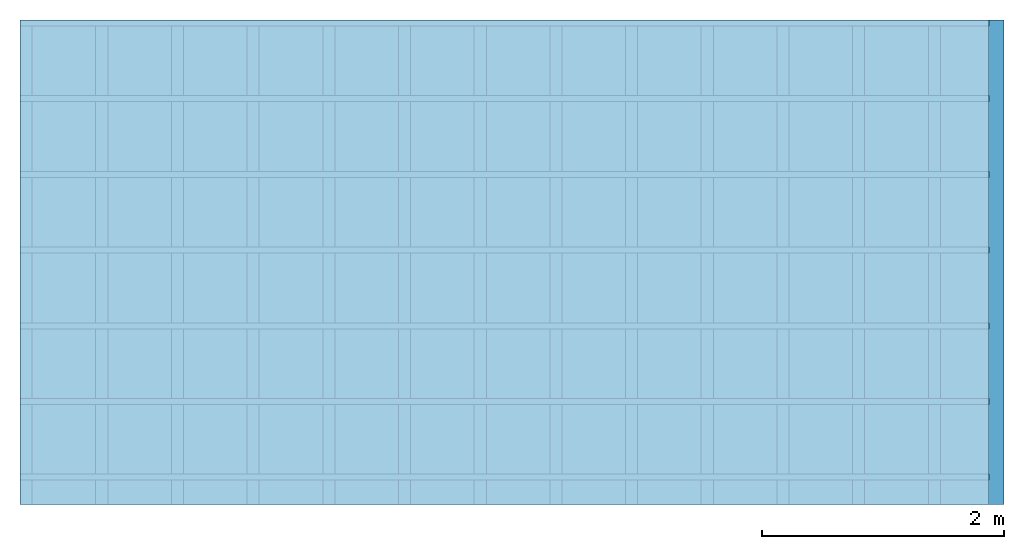
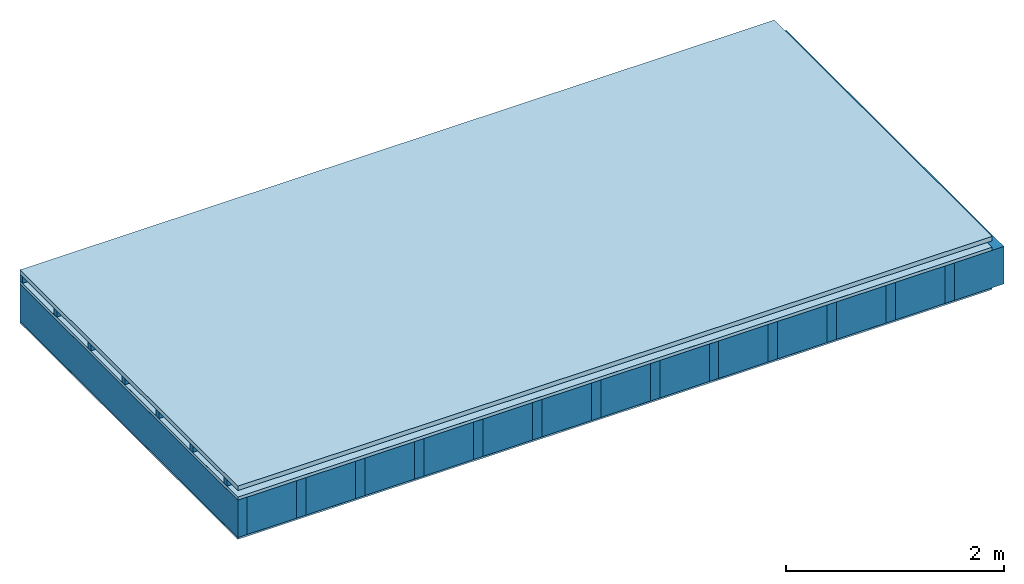
# One storey: 5 plates, 3 members, 1 element without a shape of its own.
"""IFC4 building model written with IfcOpenShell, lengths in metres."""

import ifcopenshell
import ifcopenshell.guid

model = None  # the IFC model being written
_history = None  # IfcOwnerHistory: only IFC2X3 demands one
_inside = {}  # id of a spatial element -> (the spatial element, [elements in it])
_under = {}  # id of a project, library or spatial element -> (it, [spatial elements below it])
_declared = {}  # id of a project -> (the project, [libraries it declares])
_typed = {}  # id of a type object -> (the type object, [elements of that type])
_made_of = {}  # id of a material, layer set ... -> (it, [elements and type objects made of it])


def new_model(schema):
    """Start an empty IFC model of exactly this schema.

    Asked for "IFC4X3", IfcOpenShell would pick the latest addendum, in which some entities
    have other attributes; the version numbers below select the first issue.
    IFC2X3 requires an IfcOwnerHistory on every rooted entity: one is made here for all.
    """
    global model, _history
    if schema == "IFC4X3":
        model = ifcopenshell.file(schema_version=(4, 3, 0, 0))
    else:
        model = ifcopenshell.file(schema=schema)
    _inside.clear()
    _under.clear()
    _declared.clear()
    _typed.clear()
    _made_of.clear()
    _history = None
    if model.schema == "IFC2X3":
        org = make("IfcOrganization", Name="unknown")
        user = make(
            "IfcPersonAndOrganization",
            ThePerson=make("IfcPerson", FamilyName="unknown"),
            TheOrganization=org,
        )
        app = make(
            "IfcApplication",
            ApplicationDeveloper=org,
            Version="unknown",
            ApplicationFullName="unknown",
            ApplicationIdentifier="unknown",
        )
        _history = make(
            "IfcOwnerHistory",
            OwningUser=user,
            OwningApplication=app,
            ChangeAction="ADDED",
            CreationDate=0,
        )
    return model


def make(cls, **values):
    """One entity of the class cls with the attributes given. An attribute that is None is left unset."""
    return model.create_entity(
        cls, **{name: value for name, value in values.items() if value is not None}
    )


def rooted(cls, **values):
    """An entity with a GlobalId (a new one), such as an element, a storey or a relation."""
    return make(cls, GlobalId=ifcopenshell.guid.new(), OwnerHistory=_history, **values)


def si_unit(unit_type, name, prefix=None):
    """IfcSIUnit, for example si_unit("LENGTHUNIT", "METRE", prefix="MILLI")."""
    return make("IfcSIUnit", UnitType=unit_type, Prefix=prefix, Name=name)


def derived_unit(unit_type, elements):
    """IfcDerivedUnit: a product of units, each with its exponent."""
    return make(
        "IfcDerivedUnit",
        Elements=[
            make("IfcDerivedUnitElement", Unit=unit, Exponent=power)
            for unit, power in elements
        ],
        UnitType=unit_type,
    )


def assignment(units):
    """IfcUnitAssignment: the units of a project."""
    return None if units is None else make("IfcUnitAssignment", Units=units)


def point(xyz):
    """IfcCartesianPoint."""
    return None if xyz is None else make("IfcCartesianPoint", Coordinates=xyz)


def direction(xyz):
    """IfcDirection."""
    return None if xyz is None else make("IfcDirection", DirectionRatios=xyz)


def frame(location, z_axis=None, x_axis=None):
    """IfcAxis2Placement3D, a coordinate frame: its origin and axes. An axis left out is left unset."""
    return make(
        "IfcAxis2Placement3D",
        Location=point(location),
        Axis=direction(z_axis),
        RefDirection=direction(x_axis),
    )


def frame_2d(location, x_axis=None):
    """IfcAxis2Placement2D, a coordinate frame in the plane: its origin and x axis."""
    return make(
        "IfcAxis2Placement2D", Location=point(location), RefDirection=direction(x_axis)
    )


def origin():
    """The frame at (0, 0, 0) with its axes left unset."""
    return frame((0.0, 0.0, 0.0))


def origin_with_axes():
    """The frame at (0, 0, 0) with the z axis (0, 0, 1) and the x axis (1, 0, 0) written out."""
    return frame((0.0, 0.0, 0.0), z_axis=(0.0, 0.0, 1.0), x_axis=(1.0, 0.0, 0.0))


def place(relative_to, where):
    """IfcLocalPlacement: puts the frame where relative to a parent placement (None: the world)."""
    return make(
        "IfcLocalPlacement", PlacementRelTo=relative_to, RelativePlacement=where
    )


def context(
    kind, dimensions, precision=None, world=None, true_north=None, identifier=None
):
    """IfcGeometricRepresentationContext, for example the 3D "Model" context."""
    return make(
        "IfcGeometricRepresentationContext",
        ContextIdentifier=identifier,
        ContextType=kind,
        CoordinateSpaceDimension=dimensions,
        Precision=precision,
        WorldCoordinateSystem=world,
        TrueNorth=true_north,
    )


def project(units=None, contexts=None):
    """IfcProject with its units and contexts."""
    return rooted(
        "IfcProject",
        Name="project",
        RepresentationContexts=contexts,
        UnitsInContext=assignment(units),
    )


def spatial(cls, under=None, at=None, **own):
    """A site, building, storey or space (cls), placed at a placement, below another one or the project."""
    s = rooted(cls, ObjectPlacement=at, **own)
    if under is not None:
        _under.setdefault(under.id(), (under, []))[1].append(s)
    return s


def profile(cls, at=None, kind="AREA", **sizes):
    """A parametric profile (cls). Its sizes go by their IFC names, for example OverallWidth=200.0."""
    return make(cls, ProfileType=kind, Position=at, **sizes)


def rectangle(**sizes):
    """IfcRectangleProfileDef."""
    return profile("IfcRectangleProfileDef", **sizes)


def extrude(swept, where, along, depth):
    """IfcExtrudedAreaSolid: the profile swept, set in the frame where, extruded along a direction by depth."""
    return make(
        "IfcExtrudedAreaSolid",
        SweptArea=swept,
        Position=where,
        ExtrudedDirection=direction(along),
        Depth=depth,
    )


def shape(context_of_items, identifier, shape_type, items):
    """IfcShapeRepresentation: the items that make up one representation, for example the "Body"."""
    return make(
        "IfcShapeRepresentation",
        ContextOfItems=context_of_items,
        RepresentationIdentifier=identifier,
        RepresentationType=shape_type,
        Items=items,
    )


def material(Name=None, Category=None):
    """IfcMaterial."""
    return make("IfcMaterial", Name=Name, Category=Category)


def layer(
    of_material, thickness, ventilated=None, Name=None, Category=None, Priority=None
):
    """IfcMaterialLayer: one layer of a wall or slab, of a material (None: an air gap)."""
    return make(
        "IfcMaterialLayer",
        Material=of_material,
        LayerThickness=thickness,
        IsVentilated=ventilated,
        Name=Name,
        Category=Category,
        Priority=Priority,
    )


def layer_set(layers, Name=None):
    """IfcMaterialLayerSet."""
    return make("IfcMaterialLayerSet", MaterialLayers=layers, LayerSetName=Name)


def made_of(thing, what):
    """Note that an element or type object is made of a material, layer set ...; save() writes the relation."""
    if what is not None:
        _made_of.setdefault(what.id(), (what, []))[1].append(thing)
    return thing


def type_object(cls, material=None, **own):
    """A type object (cls), such as IfcWallType, which elements share."""
    return made_of(rooted(cls, **own), material)


def element(
    cls,
    number,
    at=None,
    inside=None,
    cuts=None,
    type_object=None,
    material=None,
    context=None,
    identifier="Body",
    shape_type=None,
    held_by="IfcProductDefinitionShape",
    body=None,
    shapes=None,
    **own,
):
    """One element of the class cls, such as IfcWall. Its Tag is "e" and its number.

    at: its placement. inside: the storey or other place that contains it. cuts: it is an
    opening in that element (IfcRelVoidsElement). A single representation is given by context,
    identifier, shape_type and body (its items); several are given by shapes. held_by: the class
    of the entity that holds the representations. save() writes the other relations.
    """
    e = rooted(cls, Tag="e%d" % number, ObjectPlacement=at, **own)
    if body is not None:
        shapes = [shape(context, identifier, shape_type, body)]
    if shapes is not None:
        e.Representation = make(held_by, Representations=shapes)
    if inside is not None:
        _inside.setdefault(inside.id(), (inside, []))[1].append(e)
    if cuts is not None:
        rooted(
            "IfcRelVoidsElement", RelatingBuildingElement=cuts, RelatedOpeningElement=e
        )
    if type_object is not None:
        _typed.setdefault(type_object.id(), (type_object, []))[1].append(e)
    return made_of(e, material)


def aggregate(whole, parts):
    """IfcRelAggregates: a whole, such as a stair, and the parts it consists of."""
    return rooted("IfcRelAggregates", RelatingObject=whole, RelatedObjects=parts)


def save(model, path):
    """Write the relations noted so far, then the file.

    IfcRelAggregates (storeys below a building ...), IfcRelContainedInSpatialStructure (elements
    in a storey), IfcRelDefinesByType, IfcRelAssociatesMaterial and IfcRelDeclares: one each for
    every whole, place, type object, material and project.
    """
    for whole, parts in _under.values():
        aggregate(whole, parts)
    for where, things in _inside.values():
        rooted(
            "IfcRelContainedInSpatialStructure",
            RelatedElements=things,
            RelatingStructure=where,
        )
    for kind, things in _typed.values():
        rooted("IfcRelDefinesByType", RelatedObjects=things, RelatingType=kind)
    for what, things in _made_of.values():
        rooted("IfcRelAssociatesMaterial", RelatedObjects=things, RelatingMaterial=what)
    for by, libraries in _declared.values():
        rooted("IfcRelDeclares", RelatingContext=by, RelatedDefinitions=libraries)
    model.write(path)


model = new_model("IFC4")

# Units and contexts
plan_context = context("Plan", 3, precision=1e-05, world=origin(), true_north=direction((0.0, 1.0)))
model_context = context("Model", 3, precision=1e-05, world=origin(), true_north=direction((0.0, 1.0)))
ifc_project = project(units=[si_unit("LENGTHUNIT", "METRE"), derived_unit("SOUNDPRESSUREUNIT", [(si_unit("PRESSUREUNIT", "PASCAL", prefix="MICRO"), 0)]), si_unit("ENERGYUNIT", "JOULE", prefix="MEGA"), si_unit("MASSUNIT", "GRAM", prefix="KILO"), derived_unit("THERMALTRANSMITTANCEUNIT", [(si_unit("POWERUNIT", "WATT"), 1), (si_unit("AREAUNIT", "SQUARE_METRE"), -1), (si_unit("THERMODYNAMICTEMPERATUREUNIT", "KELVIN"), -1)]), derived_unit("AREADENSITYUNIT", [(si_unit("MASSUNIT", "GRAM", prefix="KILO"), 1), (si_unit("AREAUNIT", "SQUARE_METRE"), -1)]), derived_unit("USERDEFINED", [(si_unit("ENERGYUNIT", "JOULE", prefix="MEGA"), 1), (si_unit("AREAUNIT", "SQUARE_METRE"), -1)])], contexts=[plan_context, model_context])

# Site, building, storey
site = spatial("IfcSite", under=ifc_project)
building_placement = place(None, origin())
building = spatial("IfcBuilding", under=site, at=building_placement)
storey_placement = place(building_placement, origin())
storey = spatial("IfcBuildingStorey", under=building, at=storey_placement)

# Slab, members, plates
ifc_material_1 = material(Name="Roof tiles", Category="03.015")
ifc_layer_1 = layer(ifc_material_1, 0.05, Name="Roofing")
ifc_layer_2 = layer(None, 0.072, Name="Battens / profiles")
ifc_material_2 = material(Name="Roofing underlay", Category="09.008")
ifc_layer_3 = layer(ifc_material_2, 0.00018, Name="Under the roof")
ifc_material_3 = material(Category="10.009")
ifc_layer_4 = layer(ifc_material_3, 0.035, Name="Sub-floor")
ifc_material_4 = material(Name="of the art")
ifc_layer_5 = layer(ifc_material_4, 0.0, Name="Bond")
ifc_layer_6 = layer(None, 0.42, Name="Supporting structure")
ifc_material_5 = material(Name="Vapor barrier polyethylene (PE)", Category="09.002")
ifc_layer_7 = layer(ifc_material_5, 0.00025, Name="Vapor barrier")
ifc_material_6 = material(Name="3-layer panels", Category="07.001")
ifc_layer_8 = layer(ifc_material_6, 0.019, Name="Covering below 1st layer")
ifc_layer_set = layer_set([ifc_layer_1, ifc_layer_2, ifc_layer_3, ifc_layer_4, ifc_layer_5, ifc_layer_6, ifc_layer_7, ifc_layer_8])
slab_type = type_object("IfcSlabType", Name="E0186", PredefinedType="NOTDEFINED", material=ifc_layer_set)
slab_placement = place(None, frame((0.0, 0.0, 0.0), z_axis=(0.0, 0.0, -1.0), x_axis=(1.0, 0.0, 0.0)))
slab = element("IfcSlab", 1, at=slab_placement, inside=storey, type_object=slab_type, material=ifc_layer_set, Name="Slab #1")
ifc_material_7 = material()
member_1_placement = place(slab_placement, origin())
member_1 = element("IfcMember", 2, at=member_1_placement, material=ifc_material_7, Name="Battens / profiles", context=plan_context, shape_type="SweptSolid", body=[
    extrude(rectangle(XDim=0.05, YDim=0.072, at=frame_2d((0.025, 0.036), x_axis=(1.0, 0.0))), frame((0.0, 0.0, 0.05), z_axis=(1.0, 0.0, 0.0), x_axis=(0.0, 1.0, 0.0)), (0.0, 0.0, 1.0), 8.0),
    extrude(rectangle(XDim=0.05, YDim=0.072, at=frame_2d((0.025, 0.036), x_axis=(1.0, 0.0))), frame((0.0, 0.625, 0.05), z_axis=(1.0, 0.0, 0.0), x_axis=(0.0, 1.0, 0.0)), (0.0, 0.0, 1.0), 8.0),
    extrude(rectangle(XDim=0.05, YDim=0.072, at=frame_2d((0.025, 0.036), x_axis=(1.0, 0.0))), frame((0.0, 1.25, 0.05), z_axis=(1.0, 0.0, 0.0), x_axis=(0.0, 1.0, 0.0)), (0.0, 0.0, 1.0), 8.0),
    extrude(rectangle(XDim=0.05, YDim=0.072, at=frame_2d((0.025, 0.036), x_axis=(1.0, 0.0))), frame((0.0, 1.875, 0.05), z_axis=(1.0, 0.0, 0.0), x_axis=(0.0, 1.0, 0.0)), (0.0, 0.0, 1.0), 8.0),
    extrude(rectangle(XDim=0.05, YDim=0.072, at=frame_2d((0.025, 0.036), x_axis=(1.0, 0.0))), frame((0.0, 2.5, 0.05), z_axis=(1.0, 0.0, 0.0), x_axis=(0.0, 1.0, 0.0)), (0.0, 0.0, 1.0), 8.0),
    extrude(rectangle(XDim=0.05, YDim=0.072, at=frame_2d((0.025, 0.036), x_axis=(1.0, 0.0))), frame((0.0, 3.125, 0.05), z_axis=(1.0, 0.0, 0.0), x_axis=(0.0, 1.0, 0.0)), (0.0, 0.0, 1.0), 8.0),
    extrude(rectangle(XDim=0.05, YDim=0.072, at=frame_2d((0.025, 0.036), x_axis=(1.0, 0.0))), frame((0.0, 3.75, 0.05), z_axis=(1.0, 0.0, 0.0), x_axis=(0.0, 1.0, 0.0)), (0.0, 0.0, 1.0), 8.0),
])
ifc_material_8 = material()
member_2_placement = place(slab_placement, origin())
member_2 = element("IfcMember", 3, at=member_2_placement, material=ifc_material_8, Name="Supporting structure", context=plan_context, shape_type="SweptSolid", body=[
    extrude(rectangle(XDim=0.1, YDim=0.42, at=frame_2d((0.05, 0.21), x_axis=(1.0, 0.0))), frame((0.0, 4.0, 0.15718), z_axis=(0.0, -1.0, 0.0), x_axis=(1.0, 0.0, 0.0)), (0.0, 0.0, 1.0), 4.0),
    extrude(rectangle(XDim=0.1, YDim=0.42, at=frame_2d((0.05, 0.21), x_axis=(1.0, 0.0))), frame((0.625, 4.0, 0.15718), z_axis=(0.0, -1.0, 0.0), x_axis=(1.0, 0.0, 0.0)), (0.0, 0.0, 1.0), 4.0),
    extrude(rectangle(XDim=0.1, YDim=0.42, at=frame_2d((0.05, 0.21), x_axis=(1.0, 0.0))), frame((1.25, 4.0, 0.15718), z_axis=(0.0, -1.0, 0.0), x_axis=(1.0, 0.0, 0.0)), (0.0, 0.0, 1.0), 4.0),
    extrude(rectangle(XDim=0.1, YDim=0.42, at=frame_2d((0.05, 0.21), x_axis=(1.0, 0.0))), frame((1.875, 4.0, 0.15718), z_axis=(0.0, -1.0, 0.0), x_axis=(1.0, 0.0, 0.0)), (0.0, 0.0, 1.0), 4.0),
    extrude(rectangle(XDim=0.1, YDim=0.42, at=frame_2d((0.05, 0.21), x_axis=(1.0, 0.0))), frame((2.5, 4.0, 0.15718), z_axis=(0.0, -1.0, 0.0), x_axis=(1.0, 0.0, 0.0)), (0.0, 0.0, 1.0), 4.0),
    extrude(rectangle(XDim=0.1, YDim=0.42, at=frame_2d((0.05, 0.21), x_axis=(1.0, 0.0))), frame((3.125, 4.0, 0.15718), z_axis=(0.0, -1.0, 0.0), x_axis=(1.0, 0.0, 0.0)), (0.0, 0.0, 1.0), 4.0),
    extrude(rectangle(XDim=0.1, YDim=0.42, at=frame_2d((0.05, 0.21), x_axis=(1.0, 0.0))), frame((3.75, 4.0, 0.15718), z_axis=(0.0, -1.0, 0.0), x_axis=(1.0, 0.0, 0.0)), (0.0, 0.0, 1.0), 4.0),
    extrude(rectangle(XDim=0.1, YDim=0.42, at=frame_2d((0.05, 0.21), x_axis=(1.0, 0.0))), frame((4.375, 4.0, 0.15718), z_axis=(0.0, -1.0, 0.0), x_axis=(1.0, 0.0, 0.0)), (0.0, 0.0, 1.0), 4.0),
    extrude(rectangle(XDim=0.1, YDim=0.42, at=frame_2d((0.05, 0.21), x_axis=(1.0, 0.0))), frame((5.0, 4.0, 0.15718), z_axis=(0.0, -1.0, 0.0), x_axis=(1.0, 0.0, 0.0)), (0.0, 0.0, 1.0), 4.0),
    extrude(rectangle(XDim=0.1, YDim=0.42, at=frame_2d((0.05, 0.21), x_axis=(1.0, 0.0))), frame((5.625, 4.0, 0.15718), z_axis=(0.0, -1.0, 0.0), x_axis=(1.0, 0.0, 0.0)), (0.0, 0.0, 1.0), 4.0),
    extrude(rectangle(XDim=0.1, YDim=0.42, at=frame_2d((0.05, 0.21), x_axis=(1.0, 0.0))), frame((6.25, 4.0, 0.15718), z_axis=(0.0, -1.0, 0.0), x_axis=(1.0, 0.0, 0.0)), (0.0, 0.0, 1.0), 4.0),
    extrude(rectangle(XDim=0.1, YDim=0.42, at=frame_2d((0.05, 0.21), x_axis=(1.0, 0.0))), frame((6.875, 4.0, 0.15718), z_axis=(0.0, -1.0, 0.0), x_axis=(1.0, 0.0, 0.0)), (0.0, 0.0, 1.0), 4.0),
    extrude(rectangle(XDim=0.1, YDim=0.42, at=frame_2d((0.05, 0.21), x_axis=(1.0, 0.0))), frame((7.5, 4.0, 0.15718), z_axis=(0.0, -1.0, 0.0), x_axis=(1.0, 0.0, 0.0)), (0.0, 0.0, 1.0), 4.0),
])
ifc_material_9 = material(Name="Mineral wool")
member_3_placement = place(slab_placement, origin())
member_3 = element("IfcMember", 4, at=member_3_placement, material=ifc_material_9, Name="Cavity", context=plan_context, shape_type="SweptSolid", body=[
    extrude(rectangle(XDim=0.525, YDim=0.42, at=frame_2d((0.2625, 0.21), x_axis=(1.0, 0.0))), frame((0.1, 4.0, 0.15718), z_axis=(0.0, -1.0, 0.0), x_axis=(1.0, 0.0, 0.0)), (0.0, 0.0, 1.0), 4.0),
    extrude(rectangle(XDim=0.525, YDim=0.42, at=frame_2d((0.2625, 0.21), x_axis=(1.0, 0.0))), frame((0.725, 4.0, 0.15718), z_axis=(0.0, -1.0, 0.0), x_axis=(1.0, 0.0, 0.0)), (0.0, 0.0, 1.0), 4.0),
    extrude(rectangle(XDim=0.525, YDim=0.42, at=frame_2d((0.2625, 0.21), x_axis=(1.0, 0.0))), frame((1.35, 4.0, 0.15718), z_axis=(0.0, -1.0, 0.0), x_axis=(1.0, 0.0, 0.0)), (0.0, 0.0, 1.0), 4.0),
    extrude(rectangle(XDim=0.525, YDim=0.42, at=frame_2d((0.2625, 0.21), x_axis=(1.0, 0.0))), frame((1.975, 4.0, 0.15718), z_axis=(0.0, -1.0, 0.0), x_axis=(1.0, 0.0, 0.0)), (0.0, 0.0, 1.0), 4.0),
    extrude(rectangle(XDim=0.525, YDim=0.42, at=frame_2d((0.2625, 0.21), x_axis=(1.0, 0.0))), frame((2.6, 4.0, 0.15718), z_axis=(0.0, -1.0, 0.0), x_axis=(1.0, 0.0, 0.0)), (0.0, 0.0, 1.0), 4.0),
    extrude(rectangle(XDim=0.525, YDim=0.42, at=frame_2d((0.2625, 0.21), x_axis=(1.0, 0.0))), frame((3.225, 4.0, 0.15718), z_axis=(0.0, -1.0, 0.0), x_axis=(1.0, 0.0, 0.0)), (0.0, 0.0, 1.0), 4.0),
    extrude(rectangle(XDim=0.525, YDim=0.42, at=frame_2d((0.2625, 0.21), x_axis=(1.0, 0.0))), frame((3.85, 4.0, 0.15718), z_axis=(0.0, -1.0, 0.0), x_axis=(1.0, 0.0, 0.0)), (0.0, 0.0, 1.0), 4.0),
    extrude(rectangle(XDim=0.525, YDim=0.42, at=frame_2d((0.2625, 0.21), x_axis=(1.0, 0.0))), frame((4.475, 4.0, 0.15718), z_axis=(0.0, -1.0, 0.0), x_axis=(1.0, 0.0, 0.0)), (0.0, 0.0, 1.0), 4.0),
    extrude(rectangle(XDim=0.525, YDim=0.42, at=frame_2d((0.2625, 0.21), x_axis=(1.0, 0.0))), frame((5.1, 4.0, 0.15718), z_axis=(0.0, -1.0, 0.0), x_axis=(1.0, 0.0, 0.0)), (0.0, 0.0, 1.0), 4.0),
    extrude(rectangle(XDim=0.525, YDim=0.42, at=frame_2d((0.2625, 0.21), x_axis=(1.0, 0.0))), frame((5.725, 4.0, 0.15718), z_axis=(0.0, -1.0, 0.0), x_axis=(1.0, 0.0, 0.0)), (0.0, 0.0, 1.0), 4.0),
    extrude(rectangle(XDim=0.525, YDim=0.42, at=frame_2d((0.2625, 0.21), x_axis=(1.0, 0.0))), frame((6.35, 4.0, 0.15718), z_axis=(0.0, -1.0, 0.0), x_axis=(1.0, 0.0, 0.0)), (0.0, 0.0, 1.0), 4.0),
    extrude(rectangle(XDim=0.525, YDim=0.42, at=frame_2d((0.2625, 0.21), x_axis=(1.0, 0.0))), frame((6.975, 4.0, 0.15718), z_axis=(0.0, -1.0, 0.0), x_axis=(1.0, 0.0, 0.0)), (0.0, 0.0, 1.0), 4.0),
    extrude(rectangle(XDim=0.525, YDim=0.42, at=frame_2d((0.2625, 0.21), x_axis=(1.0, 0.0))), frame((7.6, 4.0, 0.15718), z_axis=(0.0, -1.0, 0.0), x_axis=(1.0, 0.0, 0.0)), (0.0, 0.0, 1.0), 4.0),
])
plate_1_placement = place(slab_placement, origin())
plate_1 = element("IfcPlate", 5, at=plate_1_placement, material=ifc_material_1, Name="Roofing", context=plan_context, shape_type="SweptSolid", body=[
    extrude(rectangle(XDim=8.0, YDim=4.0, at=frame_2d((4.0, 2.0), x_axis=(1.0, 0.0))), origin_with_axes(), (0.0, 0.0, 1.0), 0.05),
])
plate_2_placement = place(slab_placement, origin())
plate_2 = element("IfcPlate", 6, at=plate_2_placement, material=ifc_material_2, Name="Under the roof", context=plan_context, shape_type="SweptSolid", body=[
    extrude(rectangle(XDim=8.0, YDim=4.0, at=frame_2d((4.0, 2.0), x_axis=(1.0, 0.0))), frame((0.0, 0.0, 0.122), z_axis=(0.0, 0.0, 1.0), x_axis=(1.0, 0.0, 0.0)), (0.0, 0.0, 1.0), 0.00018),
])
plate_3_placement = place(slab_placement, origin())
plate_3 = element("IfcPlate", 7, at=plate_3_placement, material=ifc_material_3, Name="Sub-floor", context=plan_context, shape_type="SweptSolid", body=[
    extrude(rectangle(XDim=8.0, YDim=4.0, at=frame_2d((4.0, 2.0), x_axis=(1.0, 0.0))), frame((0.0, 0.0, 0.12218), z_axis=(0.0, 0.0, 1.0), x_axis=(1.0, 0.0, 0.0)), (0.0, 0.0, 1.0), 0.035),
])
plate_4_placement = place(slab_placement, origin())
plate_4 = element("IfcPlate", 8, at=plate_4_placement, material=ifc_material_5, Name="Vapor barrier", context=plan_context, shape_type="SweptSolid", body=[
    extrude(rectangle(XDim=8.0, YDim=4.0, at=frame_2d((4.0, 2.0), x_axis=(1.0, 0.0))), frame((0.0, 0.0, 0.57718), z_axis=(0.0, 0.0, 1.0), x_axis=(1.0, 0.0, 0.0)), (0.0, 0.0, 1.0), 0.00025),
])
plate_5_placement = place(slab_placement, origin())
plate_5 = element("IfcPlate", 9, at=plate_5_placement, material=ifc_material_6, Name="Covering below 1st layer", context=plan_context, shape_type="SweptSolid", body=[
    extrude(rectangle(XDim=8.0, YDim=4.0, at=frame_2d((4.0, 2.0), x_axis=(1.0, 0.0))), frame((0.0, 0.0, 0.57743), z_axis=(0.0, 0.0, 1.0), x_axis=(1.0, 0.0, 0.0)), (0.0, 0.0, 1.0), 0.019),
])
aggregate(slab, [plate_1, member_1, plate_2, plate_3, member_2, member_3, plate_4, plate_5])

save(model, "model.ifc")
